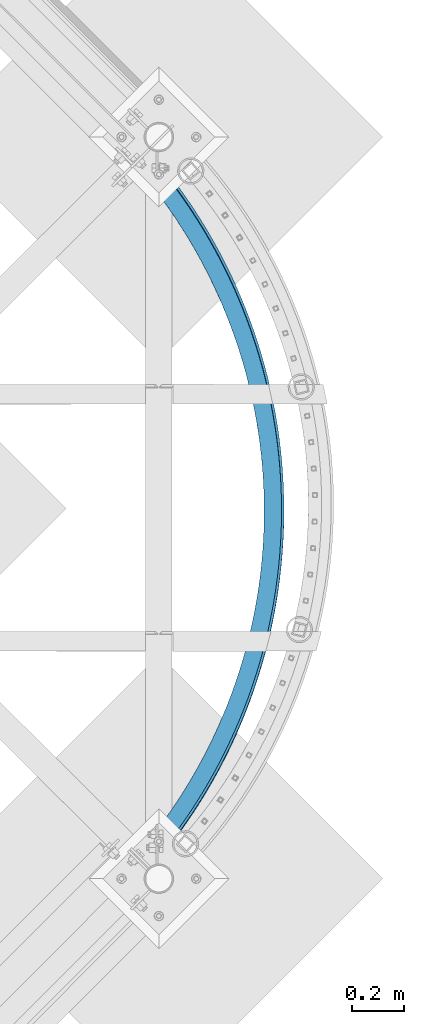
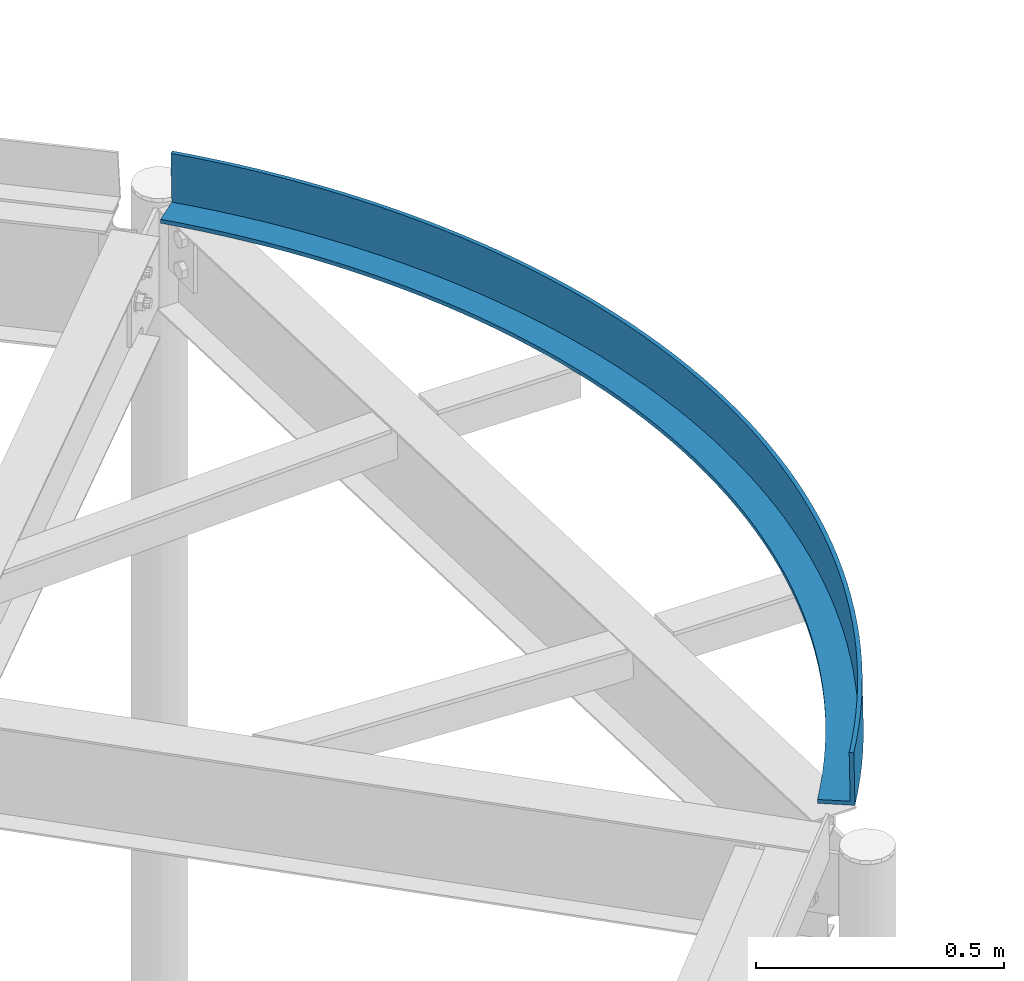
# One storey, part 371 of 975: 1 beam.
"""IFC2X3 building model written with IfcOpenShell, lengths in millimetres."""

from ifc_helpers import new_model, si_unit, frame, origin_with_axes, place, context, subcontext, project, spatial, faceted_brep, material, type_object, element, save


model = new_model("IFC2X3")

# Units and contexts
model_context = context("Model", 3, precision=1e-05, world=origin_with_axes())
body_context = subcontext(model_context, "Body", "Model", "MODEL_VIEW")
ifc_project = project(units=[si_unit("LENGTHUNIT", "METRE", prefix="MILLI"), si_unit("AREAUNIT", "SQUARE_METRE"), si_unit("VOLUMEUNIT", "CUBIC_METRE"), si_unit("MASSUNIT", "GRAM", prefix="KILO"), si_unit("TIMEUNIT", "SECOND"), si_unit("PLANEANGLEUNIT", "RADIAN"), si_unit("SOLIDANGLEUNIT", "STERADIAN"), si_unit("THERMODYNAMICTEMPERATUREUNIT", "DEGREE_CELSIUS"), si_unit("LUMINOUSINTENSITYUNIT", "LUMEN")], contexts=[model_context])

# Site, building, storey
site_placement = place(None, origin_with_axes())
site = spatial("IfcSite", under=ifc_project, at=site_placement, CompositionType="ELEMENT")
building_placement = place(site_placement, origin_with_axes())
building = spatial("IfcBuilding", under=site, at=building_placement, Name="Undefined", CompositionType="ELEMENT")
storey_placement = place(building_placement, origin_with_axes())
storey = spatial("IfcBuildingStorey", under=building, at=storey_placement, Name="Undefined", CompositionType="ELEMENT", Elevation=0.0)

# Beam
ifc_material = material(Name="STEEL/A36")
beam_type = type_object("IfcBeamType", Name="L5X3X3/8", PredefinedType="NOTDEFINED")
beam_placement = place(storey_placement, frame((35494.191845232, 12992.7484552227, 7585.68216029354), z_axis=(-0.000877678991244466, 0.0354887596459776, 0.999369690163945), x_axis=(0.024708046004611, -0.999064207186411, 0.0354996110066239)))
element("IfcBeam", 1, at=beam_placement, inside=storey, type_object=beam_type, material=ifc_material, Name="ANGLE", ObjectType="L5X3X3/8", context=body_context, shape_type="Brep", body=[
    faceted_brep([(-23.8208234743906, 29.7351369427706, -63.4999999999745), (-23.8208234743779, 29.7351369428143, 63.5000000000064), (14.224266706522, 59.504501185671, 63.5000000000064), (14.2242667065093, 59.5045011856346, -63.4999999999754), (-17.8656176057848, 22.3013527071162, 63.5000000000027), (-17.8656176057957, 22.3013527070725, -53.9749999999804), (20.0077279298821, 51.9363309128385, -53.9749999999804), (20.007727929893, 51.9363309128748, 63.5000000000018), (23.8208234743779, -29.7351369428143, -53.9750000000095), (23.8208234743779, -29.735136942807, -63.5000000000082), (60.4919564934989, -1.04086099671258, -63.5000000000082), (60.4919564934989, -1.04086099671258, -53.9750000000095), (52.940904855137, 88.3950855474686, 63.5000000000064), (52.9409048551242, 88.3950855474395, -63.4999999999745), (58.5495899049783, 80.6964962603088, -53.9749999999813), (58.5495899049893, 80.6964962603452, 63.5000000000018), (97.8103852539534, 26.8063712504372, -63.5000000000091), (97.8103852539534, 26.8063712504445, -53.9750000000104), (92.3087967947431, 116.391746393514, 63.5000000000045), (92.3087967947304, 116.391746393478, -63.4999999999773), (97.7397657555393, 108.566773476792, -53.9749999999831), (97.7397657555521, 108.566773476821, 63.5000000000009), (135.756548481198, 53.7919630599208, -63.5000000000091), (135.756548481198, 53.7919630599135, -53.9750000000122), (132.307306979636, 143.479808658769, 63.5000000000036), (132.307306979625, 143.479808658725, -63.4999999999773), (137.557713089656, 135.532553743978, -53.974999999984), (137.557713089665, 135.532553744015, 63.5), (174.310555859875, 79.9017693407222, -63.5000000000118), (174.310555859875, 79.9017693407295, -53.9750000000122), (172.915469311691, 169.645073540094, 63.5000000000018), (172.91546931168, 169.645073540065, -63.49999999998), (177.982560455188, 161.579702355579, -53.9749999999849), (177.982560455199, 161.579702355601, 63.4999999999973), (213.452198459747, 105.12210406411, -63.5000000000136), (213.452198459749, 105.122104064118, -53.9750000000149), (214.111998130218, 194.873825938921, 63.5), (214.111998130205, 194.873825938885, -63.4999999999818), (218.993118280016, 186.6945661262, -53.9749999999885), (218.993118280028, 186.694566126243, 63.4999999999945), (253.160959328678, 129.439747437405, -63.5000000000155), (253.160959328678, 129.439747437405, -53.9750000000176), (255.875299369303, 219.152841650248, 63.4999999999955), (255.875299369291, 219.152841650204, -63.4999999999854), (260.567889979007, 210.863980548114, -53.9749999999913), (260.567889979018, 210.863980548143, 63.4999999999918), (293.416024247015, 152.84195283342, -63.5000000000182), (293.416024247013, 152.841952833413, -53.9750000000195), (298.183481876815, 242.4693942944, 63.4999999999918), (298.183481876804, 242.469394294363, -63.49999999999), (302.685083221932, 234.075276691561, -53.974999999994), (302.685083221942, 234.07527669159, 63.4999999999882), (334.196292637833, 175.316453471882, -63.5000000000209), (334.196292637836, 175.316453471889, -53.975000000024), (341.014368889122, 264.811261987954, 63.4999999999891), (341.014368889111, 264.81126198791, -63.4999999999927), (345.322621356381, 256.316287845599, -53.9749999999985), (345.32262135639, 256.316287845635, 63.4999999999845), (375.480388627277, 196.851468849425, -63.5000000000264), (375.480388627278, 196.851468849432, -53.9750000000267), (384.34550965555, 286.166733749938, 63.4999999999845), (384.345509655537, 286.166733749895, -63.4999999999973), (388.458154979742, 277.575355895475, -53.9750000000031), (388.458154979751, 277.575355895511, 63.49999999998), (417.246672249166, 217.435710914462, -63.50000000003), (417.246672249166, 217.435710914477, -53.9750000000322), (428.154191206419, 306.524615640541, 63.4999999999791), (428.154191206406, 306.524615640497, -63.5000000000027), (432.069073654118, 297.841337433456, -53.9750000000076), (432.069073654129, 297.841337433492, 63.4999999999745), (459.473250788089, 237.058389984173, -63.5000000000346), (459.473250788089, 237.058389984166, -53.9750000000358), (472.417450258556, 325.874236628573, 63.4999999999736), (472.417450258543, 325.87423662853, -63.5000000000082), (476.132517758093, 317.103609599973, -53.9750000000131), (476.132517758104, 317.103609600003, 63.4999999999691), (502.137990254934, 255.709220400066, -63.50000000004), (502.137990254934, 255.709220400073, -53.9750000000413), (517.112085252, 344.205454184965, 63.4999999999682), (517.112085251987, 344.205454184928, -63.5000000000136), (520.625390469102, 335.352075651761, -53.9750000000195), (520.625390469113, 335.35207565179, 63.4999999999645), (545.218526988909, 273.378425919538, -63.5000000000446), (545.218526988909, 273.378425919538, -53.9750000000477), (562.214668511609, 361.508659599189, 63.4999999999618), (562.214668511597, 361.50865959916, -63.50000000002), (565.52436987014, 352.577170254292, -53.9750000000249), (565.524369870152, 352.577170254321, 63.4999999999573), (588.692279379944, 290.056744840207, -63.5000000000509), (588.692279379946, 290.056744840207, -53.9750000000522), (607.701558527197, 377.774783015891, 63.4999999999554), (607.701558527184, 377.774783015855, -63.5000000000264), (610.805921174457, 368.76986449572, -53.9750000000313), (610.805921174468, 368.769864495742, 63.4999999999509), (632.536459705349, 305.73543485468, -63.5000000000582), (632.53645970535, 305.735434854672, -53.9750000000586), (653.548912345741, 392.995298189002, 63.4999999999482), (653.548912345728, 392.995298188958, -63.5000000000337), (656.446309061825, 383.921670619464, -53.9750000000386), (656.446309061836, 383.921670619515, 63.4999999999445), (676.728086074485, 320.406277633039, -63.5000000000646), (676.728086074487, 320.406277633039, -53.9750000000649), (699.732698069194, 407.162226951004, 63.4999999999409), (699.732698069181, 407.162226950968, -63.5000000000409), (702.42161011994, 398.024646473423, -53.9750000000467), (702.421610119949, 398.024646473466, 63.4999999999363), (721.243994475235, 334.061583130635, -63.5000000000719), (721.243994475239, 334.061583130642, -53.9750000000731), (746.228707451333, 420.268143394867, 63.4999999999318), (746.228707451322, 420.268143394824, -63.5000000000491), (748.7077253844, 411.071399672845, -53.9750000000549), (748.707725384411, 411.071399672888, 63.4999999999291), (766.060850915934, 346.694193619005, -63.5000000000791), (766.060850915936, 346.694193619005, -53.9750000000813), (793.012568587053, 432.306177766455, 63.4999999999245), (793.012568587043, 432.306177766419, -63.5000000000573), (795.28039297071, 423.055091475326, -53.975000000064), (795.280392970721, 423.055091475369, 63.4999999999209), (811.15516365638, 358.29748743774, -63.5000000000882), (811.155163656382, 358.297487437747, -53.9750000000895), (840.059758687414, 443.270020065509, 63.4999999999154), (840.059758687399, 443.270020065473, -63.5000000000664), (842.11520079167, 433.969440365465, -53.9750000000713), (842.115200791683, 433.969440365501, 63.4999999999109), (856.503295521559, 368.865382465396, -63.5000000000964), (856.503295521559, 368.865382465403, -53.9750000000977), (887.345616933811, 453.153923353166, 63.4999999999063), (887.345616933799, 453.153923353129, -63.5000000000755), (889.187599353521, 443.808725347422, -53.9750000000813), (889.187599353532, 443.808725347466, 63.4999999999027), (902.081476291582, 378.392339307553, -63.5000000001055), (902.081476291582, 378.39233930756, -53.9750000001068), (934.845357404496, 461.952706764278, 63.4999999998954), (934.845357404483, 461.952706764241, -63.5000000000855), (936.472914624095, 452.567788943772, -53.9750000000904), (936.472914624108, 452.567788943801, 63.4999999998918), (947.865815161376, 386.873364200423, -63.5000000001146), (947.865815161376, 386.87336420043, -53.9750000001159), (982.534082066644, 469.661758223185, 63.4999999998854), (982.534082066635, 469.661758223141, -63.5000000000964), (983.946360966251, 460.242039898811, -53.9750000001004), (983.946360966262, 460.242039898847, 63.4999999998818), (993.83231326356, 394.304011628425, -63.5000000001246), (993.832313263563, 394.304011628425, -53.9750000001268), (1030.38679382722, 476.277036861138, 63.4999999998745), (1030.38679382721, 476.277036861102, -63.5000000001064), (1031.58305412981, 466.827455585269, -53.9750000001113), (1031.58305412982, 466.827455585313, 63.4999999998709), (1039.956876248, 400.680386654414, -63.5000000001355), (1039.956876248, 400.680386654414, -53.9750000001359), (1078.37840963574, 481.795075134469, 63.4999999998636), (1078.37840963573, 481.795075134425, -63.5000000001182), (1079.35802429519, 472.320584112793, -53.9750000001222), (1079.3580242952, 472.320584112829, 63.4999999998599), (1086.21532691138, 405.999146961294, -63.5000000001455), (1086.21532691138, 405.999146961301, -53.9750000001468), (1126.48377363213, 486.212980642144, 63.4999999998527), (1126.48377363211, 486.2129806421, -63.5000000001291), (1127.24622916188, 476.718546137345, -53.9750000001341), (1127.24622916188, 476.718546137381, 63.499999999849), (1132.5834178702, 410.257504603964, -63.5000000001564), (1132.5834178702, 410.257504603964, -53.9750000001586), (1174.67767033266, 489.528437641908, 63.4999999998408), (1174.67767033265, 489.528437641864, -63.500000000141), (1175.2225670749, 480.019036370475, -53.9750000001468), (1175.22256707491, 480.019036370511, 63.4999999998381), (1179.0368442706, 413.45322747068, -63.5000000001683), (1179.0368442706, 413.453227470673, -53.9750000001686), (1222.93483784729, 491.739708264104, 63.4999999998281), (1222.93483784728, 491.739708264067, -63.5000000001537), (1223.2618901824, 482.220324787697, -53.9750000001586), (1223.26189018242, 482.220324787733, 63.4999999998254), (1225.55125652828, 415.584640453075, -63.5000000001801), (1225.55125652828, 415.584640453082, -53.9750000001814), (1271.22998112116, 492.845633422658, 63.4999999998163), (1271.22998112114, 492.845633422621, -63.5000000001655), (1271.33901761748, 483.321257535325, -53.9750000001713), (1271.33901761749, 483.321257535361, 63.4999999998126), (1272.10227309184, 416.650626324212, -63.5000000001919), (1272.10227309184, 416.650626324204, -53.9750000001932), (1319.53778519358, 492.845633422585, 63.4999999998026), (1319.53778519357, 492.845633422541, -63.5000000001792), (1319.42874869724, 483.321257535252, -53.9750000001832), (1319.42874869726, 483.321257535281, 63.4999999997999), (1318.66549322296, 416.650626324132, -63.5000000002046), (1318.66549322296, 416.650626324124, -53.9750000002068), (1367.83292846745, 491.739708263878, 63.499999999789), (1367.83292846744, 491.739708263849, -63.5000000001928), (1367.50587613232, 482.220324787479, -53.9750000001968), (1367.50587613233, 482.220324787508, 63.4999999997863), (1365.21650978653, 415.584640452864, -63.5000000002174), (1365.21650978653, 415.584640452864, -53.9750000002196), (1416.09009598208, 489.528437641529, 63.4999999997744), (1416.09009598206, 489.5284376415, -63.5000000002065), (1415.54519923983, 480.019036370104, -53.9750000002114), (1415.54519923985, 480.019036370133, 63.4999999997726), (1411.7309220442, 413.453227470323, -63.500000000231), (1411.7309220442, 413.453227470323, -53.9750000002323), (1464.28399268262, 486.21298064162, 63.4999999997608), (1464.2839926826, 486.212980641583, -63.500000000221), (1463.52153715286, 476.718546136828, -53.975000000225), (1463.52153715287, 476.718546136857, 63.499999999759), (1458.18434844461, 410.257504603462, -63.5000000002447), (1458.18434844461, 410.257504603469, -53.9750000002459), (1512.389356679, 481.795075133807, 63.4999999997463), (1512.38935667899, 481.79507513377, -63.5000000002346), (1511.40974201955, 472.320584112123, -53.9750000002387), (1511.40974201956, 472.320584112167, 63.4999999997435), (1504.55243940344, 405.999146960647, -63.5000000002583), (1504.55243940343, 405.999146960654, -53.9750000002587), (1560.38097248753, 476.277036860331, 63.4999999997317), (1560.38097248752, 476.277036860287, -63.5000000002492), (1559.18471218494, 466.827455584462, -53.9750000002541), (1559.18471218495, 466.827455584498, 63.4999999997281), (1550.81089006682, 400.680386653636, -63.5000000002728), (1550.81089006682, 400.680386653628, -53.9750000002732), (1608.23368424812, 469.661758222224, 63.4999999997162), (1608.23368424811, 469.661758222188, -63.5000000002656), (1606.8214053485, 460.24203989785, -53.9750000002696), (1606.82140534851, 460.242039897887, 63.4999999997144), (1596.93545305126, 394.304011627501, -63.5000000002883), (1596.93545305127, 394.304011627508, -53.9750000002887), (1655.92240891028, 461.952706763179, 63.4999999997017), (1655.92240891026, 461.952706763135, -63.5000000002801), (1654.29485169067, 452.567788942666, -53.9750000002841), (1654.29485169068, 452.567788942702, 63.499999999698), (1642.90195115346, 386.87336419936, -63.500000000302), (1642.90195115346, 386.873364199368, -53.9750000003041), (1703.42214938097, 453.153923351914, 63.4999999996853), (1703.42214938096, 453.153923351871, -63.5000000002956), (1701.58016696125, 443.808725346185, -53.9750000003005), (1701.58016696126, 443.808725346222, 63.4999999996826), (1688.68629002327, 378.392339306345, -63.5000000003183), (1688.68629002327, 378.392339306352, -53.9750000003196), (1750.70800762738, 443.270020064112, 63.4999999996689), (1750.70800762737, 443.270020064068, -63.500000000312), (1748.65256552311, 433.969440364075, -53.9750000003169), (1748.65256552312, 433.969440364112, 63.499999999668), (1734.2644707933, 368.86538246405, -63.5000000003329), (1734.2644707933, 368.865382464057, -53.9750000003341), (1797.75519772775, 432.306177764913, 63.4999999996526), (1797.75519772774, 432.306177764869, -63.5000000003283), (1795.48737334409, 423.055091473791, -53.9750000003323), (1795.4873733441, 423.055091473827, 63.4999999996508), (1779.61260265849, 358.297487436255, -63.5000000003492), (1779.61260265849, 358.297487436263, -53.9750000003496), (1844.53905886349, 420.268143393179, 63.4999999996362), (1844.53905886347, 420.268143393143, -63.5000000003456), (1842.06004093041, 411.071399671164, -53.9750000003487), (1842.06004093042, 411.0713996712, 63.4999999996335), (1824.70691539895, 346.694193617375, -63.5000000003656), (1824.70691539895, 346.694193617383, -53.9750000003669), (1891.03506824564, 407.162226949178, 63.4999999996198), (1891.03506824563, 407.162226949142, -63.500000000362), (1888.34615619489, 398.024646471604, -53.9750000003669), (1888.3461561949, 398.024646471647, 63.4999999996162), (1869.52377183966, 334.061583128874, -63.5000000003811), (1869.52377183966, 334.061583128874, -53.9750000003833), (1937.21885396912, 392.995298187023, 63.4999999996026), (1937.2188539691, 392.995298186994, -63.5000000003793), (1934.32145725302, 383.921670617514, -53.9750000003842), (1934.32145725303, 383.92167061755, 63.4999999995989), (1914.03968024043, 320.40627763114, -63.5000000003984), (1914.03968024043, 320.406277631133, -53.9750000003996), (1983.06620778768, 377.774783013789, 63.4999999995844), (1983.06620778766, 377.774783013745, -63.5000000003974), (1979.9618451404, 368.769864493617, -53.9750000004015), (1979.96184514041, 368.769864493646, 63.4999999995825), (1958.23130660958, 305.735434852642, -63.5000000004156), (1958.23130660958, 305.735434852642, -53.975000000416), (2028.55309780328, 361.508659596948, 63.4999999995662), (2028.55309780327, 361.508659596904, -63.5000000004147), (2025.24339644474, 352.577170252051, -53.9750000004187), (2025.24339644475, 352.577170252087, 63.4999999995644), (2002.07548693501, 290.056744838032, -63.500000000432), (2002.07548693501, 290.056744838039, -53.9750000004342), (2073.65568106291, 344.205454182571, 63.4999999995489), (2073.6556810629, 344.205454182535, -63.5000000004329), (2070.1423758458, 335.352075649382, -53.975000000436), (2070.14237584581, 335.352075649411, 63.4999999995462), (2045.54923932606, 273.378425917239, -63.5000000004493), (2045.54923932606, 273.378425917239, -53.9750000004524), (2118.35031605638, 325.874236626049, 63.4999999995307), (2118.35031605637, 325.874236626005, -63.5000000004511), (2114.63524855683, 317.103609597463, -53.9750000004551), (2114.63524855684, 317.103609597492, 63.499999999528), (2088.62977606006, 255.709220397635, -63.5000000004675), (2088.62977606006, 255.709220397635, -53.9750000004688), (2162.61357510854, 306.524615637871, 63.4999999995116), (2162.61357510853, 306.524615637834, -63.5000000004702), (2158.69869266082, 297.841337430807, -53.9750000004733), (2158.69869266084, 297.841337430844, 63.4999999995098), (2131.29451552692, 237.058389981605, -63.5000000004857), (2131.29451552692, 237.058389981597, -53.975000000486), (2206.42225665943, 286.166733747137, 63.4999999994925), (2206.42225665942, 286.166733747108, -63.5000000004893), (2202.30961133523, 277.575355892695, -53.9750000004924), (2202.30961133524, 277.575355892724, 63.4999999994907), (2173.52109406587, 217.43571091177, -63.5000000005039), (2173.52109406587, 217.435710911785, -53.9750000005051), (2249.75339742588, 264.811261985022, 63.4999999994734), (2249.75339742587, 264.811261984978, -63.5000000005075), (2245.44514495861, 256.316287842688, -53.9750000005115), (2245.44514495862, 256.316287842725, 63.4999999994725), (2215.28737768778, 196.851468846602, -63.5000000005211), (2215.28737768778, 196.851468846609, -53.9750000005233), (2292.58428443822, 242.469394291344, 63.4999999994552), (2292.58428443821, 242.469394291315, -63.5000000005266), (2288.08268309309, 234.075276688513, -53.9750000005297), (2288.0826830931, 234.075276688549, 63.4999999994534), (2256.57147367725, 175.316453468942, -63.5000000005402), (2256.57147367725, 175.316453468935, -53.9750000005415), (2334.89246694576, 219.152841647046, 63.4999999994352), (2334.89246694574, 219.152841647017, -63.5000000005457), (2330.19987633604, 210.863980544927, -53.9750000005497), (2330.19987633605, 210.863980544957, 63.4999999994334), (2297.3517420681, 152.841952830335, -63.5000000005593), (2297.3517420681, 152.841952830335, -53.9750000005606), (2376.65576818487, 194.873825935603, 63.4999999994152), (2376.65576818486, 194.873825935567, -63.5000000005648), (2371.77464803506, 186.694566122904, -53.9750000005679), (2371.77464803507, 186.69456612294, 63.4999999994143), (2337.60680698646, 129.439747434211, -63.5000000005775), (2337.60680698646, 129.439747434211, -53.9750000005788), (2417.85229700343, 169.64507353666, 63.4999999993961), (2417.85229700342, 169.645073536623, -63.5000000005857), (2412.78520585992, 161.579702352145, -53.9750000005888), (2412.78520585993, 161.579702352181, 63.4999999993943), (2377.31556785542, 105.122104060792, -63.5000000005975), (2377.31556785542, 105.122104060807, -53.9750000005979), (2458.46045933551, 143.479808655196, 63.499999999377), (2458.4604593355, 143.47980865516, -63.5000000006048), (2453.21005322548, 135.532553740428, -53.9750000006088), (2453.21005322549, 135.532553740457, 63.4999999993743), (2416.45721045533, 79.9017693372807, -63.5000000006157), (2416.45721045533, 79.901769337288, -53.9750000006179), (2498.45896952044, 116.391746389825, 63.4999999993552), (2498.45896952042, 116.391746389789, -63.5000000006266), (2493.02800055963, 108.566773473118, -53.9750000006279), (2493.02800055964, 108.56677347314, 63.4999999993543), (2455.01121783403, 53.7919630563556, -63.5000000006348), (2455.01121783403, 53.7919630563629, -53.975000000637), (2537.82686146008, 88.395085543656, 63.4999999993352), (2537.82686146007, 88.3950855436196, -63.5000000006467), (2532.21817641022, 80.696496256518, -53.9750000006488), (2532.21817641023, 80.6964962565544, 63.4999999993342), (2492.95738106131, 26.8063712467629, -63.5000000006539), (2492.95738106131, 26.8063712467701, -53.975000000657), (2576.54349960873, 59.5045011817419, 63.4999999993152), (2576.54349960872, 59.5045011816983, -63.5000000006667), (2570.76003838535, 51.9363309089313, -53.9750000006688), (2570.76003838536, 51.9363309089604, 63.4999999993142), (2530.2758098218, -1.04086100049608, -63.5000000006739), (2530.2758098218, -1.04086100050336, -53.9750000006761), (2614.58858978966, 29.7351369387616, 63.4999999992951), (2614.58858978965, 29.7351369387252, -63.5000000006867), (2608.63338392107, 22.301352703078, 63.4999999992942), (2608.63338392107, 22.3013527030416, -53.9750000006889), (2566.94694284095, -29.7351369467069, -53.9750000006952), (2566.94694284095, -29.7351369467069, -63.5000000006949)], [[[0, 1, 2, 3]], [[4, 5, 6, 7]], [[8, 9, 10, 11]], [[9, 8, 5, 4, 1, 0]], [[3, 2, 12, 13]], [[7, 6, 14, 15]], [[11, 10, 16, 17]], [[13, 12, 18, 19]], [[15, 14, 20, 21]], [[17, 16, 22, 23]], [[19, 18, 24, 25]], [[21, 20, 26, 27]], [[23, 22, 28, 29]], [[25, 24, 30, 31]], [[27, 26, 32, 33]], [[29, 28, 34, 35]], [[31, 30, 36, 37]], [[33, 32, 38, 39]], [[35, 34, 40, 41]], [[37, 36, 42, 43]], [[39, 38, 44, 45]], [[41, 40, 46, 47]], [[43, 42, 48, 49]], [[45, 44, 50, 51]], [[47, 46, 52, 53]], [[49, 48, 54, 55]], [[51, 50, 56, 57]], [[53, 52, 58, 59]], [[55, 54, 60, 61]], [[57, 56, 62, 63]], [[59, 58, 64, 65]], [[61, 60, 66, 67]], [[63, 62, 68, 69]], [[65, 64, 70, 71]], [[67, 66, 72, 73]], [[69, 68, 74, 75]], [[71, 70, 76, 77]], [[73, 72, 78, 79]], [[75, 74, 80, 81]], [[77, 76, 82, 83]], [[79, 78, 84, 85]], [[81, 80, 86, 87]], [[83, 82, 88, 89]], [[85, 84, 90, 91]], [[87, 86, 92, 93]], [[89, 88, 94, 95]], [[91, 90, 96, 97]], [[93, 92, 98, 99]], [[95, 94, 100, 101]], [[97, 96, 102, 103]], [[99, 98, 104, 105]], [[101, 100, 106, 107]], [[103, 102, 108, 109]], [[105, 104, 110, 111]], [[107, 106, 112, 113]], [[109, 108, 114, 115]], [[111, 110, 116, 117]], [[113, 112, 118, 119]], [[115, 114, 120, 121]], [[117, 116, 122, 123]], [[119, 118, 124, 125]], [[121, 120, 126, 127]], [[123, 122, 128, 129]], [[125, 124, 130, 131]], [[127, 126, 132, 133]], [[129, 128, 134, 135]], [[131, 130, 136, 137]], [[133, 132, 138, 139]], [[135, 134, 140, 141]], [[137, 136, 142, 143]], [[139, 138, 144, 145]], [[141, 140, 146, 147]], [[143, 142, 148, 149]], [[145, 144, 150, 151]], [[147, 146, 152, 153]], [[149, 148, 154, 155]], [[151, 150, 156, 157]], [[153, 152, 158, 159]], [[155, 154, 160, 161]], [[157, 156, 162, 163]], [[159, 158, 164, 165]], [[161, 160, 166, 167]], [[163, 162, 168, 169]], [[165, 164, 170, 171]], [[167, 166, 172, 173]], [[169, 168, 174, 175]], [[171, 170, 176, 177]], [[173, 172, 178, 179]], [[175, 174, 180, 181]], [[177, 176, 182, 183]], [[179, 178, 184, 185]], [[181, 180, 186, 187]], [[183, 182, 188, 189]], [[185, 184, 190, 191]], [[187, 186, 192, 193]], [[189, 188, 194, 195]], [[191, 190, 196, 197]], [[193, 192, 198, 199]], [[195, 194, 200, 201]], [[197, 196, 202, 203]], [[199, 198, 204, 205]], [[201, 200, 206, 207]], [[203, 202, 208, 209]], [[205, 204, 210, 211]], [[207, 206, 212, 213]], [[209, 208, 214, 215]], [[211, 210, 216, 217]], [[213, 212, 218, 219]], [[215, 214, 220, 221]], [[217, 216, 222, 223]], [[219, 218, 224, 225]], [[221, 220, 226, 227]], [[223, 222, 228, 229]], [[225, 224, 230, 231]], [[227, 226, 232, 233]], [[229, 228, 234, 235]], [[231, 230, 236, 237]], [[233, 232, 238, 239]], [[235, 234, 240, 241]], [[237, 236, 242, 243]], [[239, 238, 244, 245]], [[241, 240, 246, 247]], [[243, 242, 248, 249]], [[245, 244, 250, 251]], [[247, 246, 252, 253]], [[249, 248, 254, 255]], [[251, 250, 256, 257]], [[253, 252, 258, 259]], [[255, 254, 260, 261]], [[257, 256, 262, 263]], [[259, 258, 264, 265]], [[261, 260, 266, 267]], [[263, 262, 268, 269]], [[265, 264, 270, 271]], [[267, 266, 272, 273]], [[269, 268, 274, 275]], [[271, 270, 276, 277]], [[273, 272, 278, 279]], [[275, 274, 280, 281]], [[277, 276, 282, 283]], [[279, 278, 284, 285]], [[281, 280, 286, 287]], [[283, 282, 288, 289]], [[285, 284, 290, 291]], [[287, 286, 292, 293]], [[289, 288, 294, 295]], [[291, 290, 296, 297]], [[293, 292, 298, 299]], [[295, 294, 300, 301]], [[297, 296, 302, 303]], [[299, 298, 304, 305]], [[301, 300, 306, 307]], [[303, 302, 308, 309]], [[305, 304, 310, 311]], [[307, 306, 312, 313]], [[309, 308, 314, 315]], [[311, 310, 316, 317]], [[313, 312, 318, 319]], [[315, 314, 320, 321]], [[317, 316, 322, 323]], [[319, 318, 324, 325]], [[321, 320, 326, 327]], [[323, 322, 328, 329]], [[325, 324, 330, 331]], [[327, 326, 332, 333]], [[329, 328, 334, 335]], [[331, 330, 336, 337]], [[333, 332, 338, 339]], [[335, 334, 340, 341]], [[337, 336, 342, 343]], [[339, 338, 344, 345]], [[341, 340, 346, 347]], [[343, 342, 348, 349]], [[345, 344, 350, 351]], [[347, 346, 352, 353]], [[349, 348, 354, 355]], [[348, 342, 336, 330, 324, 318, 312, 306, 300, 294, 288, 282, 276, 270, 264, 258, 252, 246, 240, 234, 228, 222, 216, 210, 204, 198, 192, 186, 180, 174, 168, 162, 156, 150, 144, 138, 132, 126, 120, 114, 108, 102, 96, 90, 84, 78, 72, 66, 60, 54, 48, 42, 36, 30, 24, 18, 12, 2, 1, 4, 7, 15, 21, 27, 33, 39, 45, 51, 57, 63, 69, 75, 81, 87, 93, 99, 105, 111, 117, 123, 129, 135, 141, 147, 153, 159, 165, 171, 177, 183, 189, 195, 201, 207, 213, 219, 225, 231, 237, 243, 249, 255, 261, 267, 273, 279, 285, 291, 297, 303, 309, 315, 321, 327, 333, 339, 345, 351, 356, 354]], [[351, 350, 357, 356]], [[350, 344, 338, 332, 326, 320, 314, 308, 302, 296, 290, 284, 278, 272, 266, 260, 254, 248, 242, 236, 230, 224, 218, 212, 206, 200, 194, 188, 182, 176, 170, 164, 158, 152, 146, 140, 134, 128, 122, 116, 110, 104, 98, 92, 86, 80, 74, 68, 62, 56, 50, 44, 38, 32, 26, 20, 14, 6, 5, 8, 11, 17, 23, 29, 35, 41, 47, 53, 59, 65, 71, 77, 83, 89, 95, 101, 107, 113, 119, 125, 131, 137, 143, 149, 155, 161, 167, 173, 179, 185, 191, 197, 203, 209, 215, 221, 227, 233, 239, 245, 251, 257, 263, 269, 275, 281, 287, 293, 299, 305, 311, 317, 323, 329, 335, 341, 347, 353, 358, 357]], [[353, 352, 359, 358]], [[352, 346, 340, 334, 328, 322, 316, 310, 304, 298, 292, 286, 280, 274, 268, 262, 256, 250, 244, 238, 232, 226, 220, 214, 208, 202, 196, 190, 184, 178, 172, 166, 160, 154, 148, 142, 136, 130, 124, 118, 112, 106, 100, 94, 88, 82, 76, 70, 64, 58, 52, 46, 40, 34, 28, 22, 16, 10, 9, 0, 3, 13, 19, 25, 31, 37, 43, 49, 55, 61, 67, 73, 79, 85, 91, 97, 103, 109, 115, 121, 127, 133, 139, 145, 151, 157, 163, 169, 175, 181, 187, 193, 199, 205, 211, 217, 223, 229, 235, 241, 247, 253, 259, 265, 271, 277, 283, 289, 295, 301, 307, 313, 319, 325, 331, 337, 343, 349, 355, 359]], [[356, 357, 358, 359, 355, 354]]]),
])

save(model, "model.ifc")
